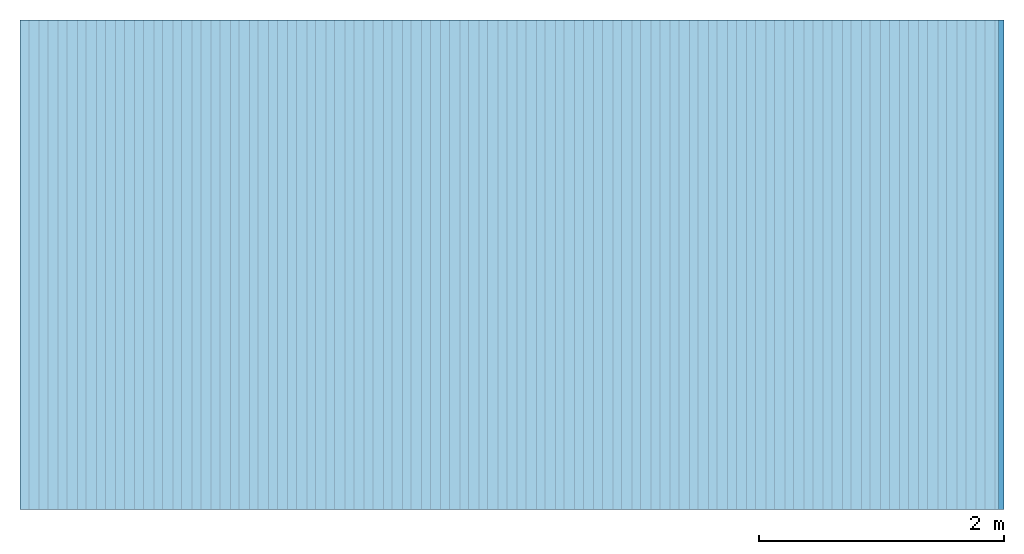
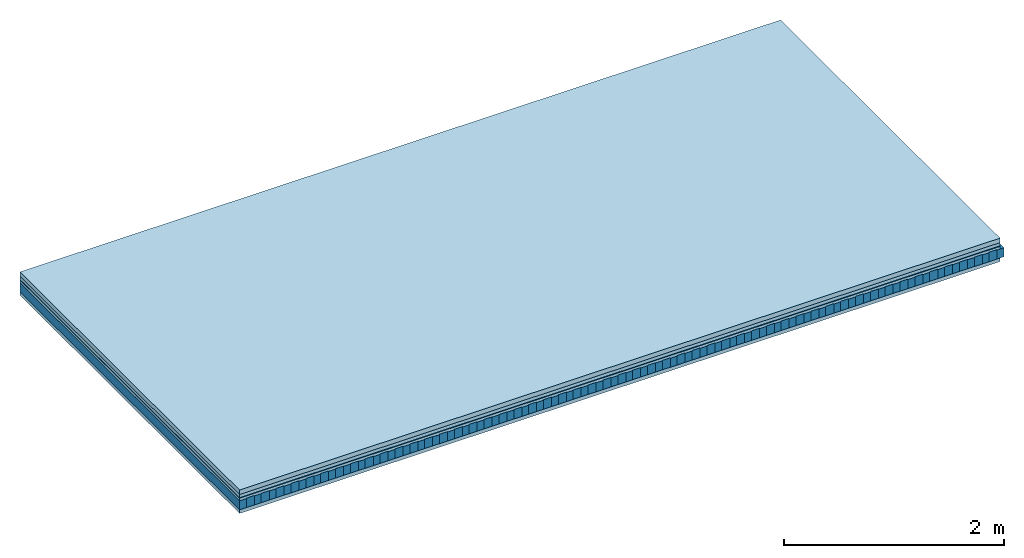
# One storey: 5 plates, 2 members, 1 element without a shape of its own.
"""IFC4 building model written with IfcOpenShell, lengths in metres."""

import ifcopenshell
import ifcopenshell.guid

model = None  # the IFC model being written
_history = None  # IfcOwnerHistory: only IFC2X3 demands one
_inside = {}  # id of a spatial element -> (the spatial element, [elements in it])
_under = {}  # id of a project, library or spatial element -> (it, [spatial elements below it])
_declared = {}  # id of a project -> (the project, [libraries it declares])
_typed = {}  # id of a type object -> (the type object, [elements of that type])
_made_of = {}  # id of a material, layer set ... -> (it, [elements and type objects made of it])


def new_model(schema):
    """Start an empty IFC model of exactly this schema.

    Asked for "IFC4X3", IfcOpenShell would pick the latest addendum, in which some entities
    have other attributes; the version numbers below select the first issue.
    IFC2X3 requires an IfcOwnerHistory on every rooted entity: one is made here for all.
    """
    global model, _history
    if schema == "IFC4X3":
        model = ifcopenshell.file(schema_version=(4, 3, 0, 0))
    else:
        model = ifcopenshell.file(schema=schema)
    _inside.clear()
    _under.clear()
    _declared.clear()
    _typed.clear()
    _made_of.clear()
    _history = None
    if model.schema == "IFC2X3":
        org = make("IfcOrganization", Name="unknown")
        user = make(
            "IfcPersonAndOrganization",
            ThePerson=make("IfcPerson", FamilyName="unknown"),
            TheOrganization=org,
        )
        app = make(
            "IfcApplication",
            ApplicationDeveloper=org,
            Version="unknown",
            ApplicationFullName="unknown",
            ApplicationIdentifier="unknown",
        )
        _history = make(
            "IfcOwnerHistory",
            OwningUser=user,
            OwningApplication=app,
            ChangeAction="ADDED",
            CreationDate=0,
        )
    return model


def make(cls, **values):
    """One entity of the class cls with the attributes given. An attribute that is None is left unset."""
    return model.create_entity(
        cls, **{name: value for name, value in values.items() if value is not None}
    )


def rooted(cls, **values):
    """An entity with a GlobalId (a new one), such as an element, a storey or a relation."""
    return make(cls, GlobalId=ifcopenshell.guid.new(), OwnerHistory=_history, **values)


def si_unit(unit_type, name, prefix=None):
    """IfcSIUnit, for example si_unit("LENGTHUNIT", "METRE", prefix="MILLI")."""
    return make("IfcSIUnit", UnitType=unit_type, Prefix=prefix, Name=name)


def derived_unit(unit_type, elements):
    """IfcDerivedUnit: a product of units, each with its exponent."""
    return make(
        "IfcDerivedUnit",
        Elements=[
            make("IfcDerivedUnitElement", Unit=unit, Exponent=power)
            for unit, power in elements
        ],
        UnitType=unit_type,
    )


def assignment(units):
    """IfcUnitAssignment: the units of a project."""
    return None if units is None else make("IfcUnitAssignment", Units=units)


def point(xyz):
    """IfcCartesianPoint."""
    return None if xyz is None else make("IfcCartesianPoint", Coordinates=xyz)


def direction(xyz):
    """IfcDirection."""
    return None if xyz is None else make("IfcDirection", DirectionRatios=xyz)


def frame(location, z_axis=None, x_axis=None):
    """IfcAxis2Placement3D, a coordinate frame: its origin and axes. An axis left out is left unset."""
    return make(
        "IfcAxis2Placement3D",
        Location=point(location),
        Axis=direction(z_axis),
        RefDirection=direction(x_axis),
    )


def frame_2d(location, x_axis=None):
    """IfcAxis2Placement2D, a coordinate frame in the plane: its origin and x axis."""
    return make(
        "IfcAxis2Placement2D", Location=point(location), RefDirection=direction(x_axis)
    )


def origin():
    """The frame at (0, 0, 0) with its axes left unset."""
    return frame((0.0, 0.0, 0.0))


def origin_with_axes():
    """The frame at (0, 0, 0) with the z axis (0, 0, 1) and the x axis (1, 0, 0) written out."""
    return frame((0.0, 0.0, 0.0), z_axis=(0.0, 0.0, 1.0), x_axis=(1.0, 0.0, 0.0))


def place(relative_to, where):
    """IfcLocalPlacement: puts the frame where relative to a parent placement (None: the world)."""
    return make(
        "IfcLocalPlacement", PlacementRelTo=relative_to, RelativePlacement=where
    )


def context(
    kind, dimensions, precision=None, world=None, true_north=None, identifier=None
):
    """IfcGeometricRepresentationContext, for example the 3D "Model" context."""
    return make(
        "IfcGeometricRepresentationContext",
        ContextIdentifier=identifier,
        ContextType=kind,
        CoordinateSpaceDimension=dimensions,
        Precision=precision,
        WorldCoordinateSystem=world,
        TrueNorth=true_north,
    )


def project(units=None, contexts=None):
    """IfcProject with its units and contexts."""
    return rooted(
        "IfcProject",
        Name="project",
        RepresentationContexts=contexts,
        UnitsInContext=assignment(units),
    )


def spatial(cls, under=None, at=None, **own):
    """A site, building, storey or space (cls), placed at a placement, below another one or the project."""
    s = rooted(cls, ObjectPlacement=at, **own)
    if under is not None:
        _under.setdefault(under.id(), (under, []))[1].append(s)
    return s


def profile(cls, at=None, kind="AREA", **sizes):
    """A parametric profile (cls). Its sizes go by their IFC names, for example OverallWidth=200.0."""
    return make(cls, ProfileType=kind, Position=at, **sizes)


def rectangle(**sizes):
    """IfcRectangleProfileDef."""
    return profile("IfcRectangleProfileDef", **sizes)


def extrude(swept, where, along, depth):
    """IfcExtrudedAreaSolid: the profile swept, set in the frame where, extruded along a direction by depth."""
    return make(
        "IfcExtrudedAreaSolid",
        SweptArea=swept,
        Position=where,
        ExtrudedDirection=direction(along),
        Depth=depth,
    )


def shape(context_of_items, identifier, shape_type, items):
    """IfcShapeRepresentation: the items that make up one representation, for example the "Body"."""
    return make(
        "IfcShapeRepresentation",
        ContextOfItems=context_of_items,
        RepresentationIdentifier=identifier,
        RepresentationType=shape_type,
        Items=items,
    )


def material(Name=None, Category=None):
    """IfcMaterial."""
    return make("IfcMaterial", Name=Name, Category=Category)


def layer(
    of_material, thickness, ventilated=None, Name=None, Category=None, Priority=None
):
    """IfcMaterialLayer: one layer of a wall or slab, of a material (None: an air gap)."""
    return make(
        "IfcMaterialLayer",
        Material=of_material,
        LayerThickness=thickness,
        IsVentilated=ventilated,
        Name=Name,
        Category=Category,
        Priority=Priority,
    )


def layer_set(layers, Name=None):
    """IfcMaterialLayerSet."""
    return make("IfcMaterialLayerSet", MaterialLayers=layers, LayerSetName=Name)


def made_of(thing, what):
    """Note that an element or type object is made of a material, layer set ...; save() writes the relation."""
    if what is not None:
        _made_of.setdefault(what.id(), (what, []))[1].append(thing)
    return thing


def type_object(cls, material=None, **own):
    """A type object (cls), such as IfcWallType, which elements share."""
    return made_of(rooted(cls, **own), material)


def element(
    cls,
    number,
    at=None,
    inside=None,
    cuts=None,
    type_object=None,
    material=None,
    context=None,
    identifier="Body",
    shape_type=None,
    held_by="IfcProductDefinitionShape",
    body=None,
    shapes=None,
    **own,
):
    """One element of the class cls, such as IfcWall. Its Tag is "e" and its number.

    at: its placement. inside: the storey or other place that contains it. cuts: it is an
    opening in that element (IfcRelVoidsElement). A single representation is given by context,
    identifier, shape_type and body (its items); several are given by shapes. held_by: the class
    of the entity that holds the representations. save() writes the other relations.
    """
    e = rooted(cls, Tag="e%d" % number, ObjectPlacement=at, **own)
    if body is not None:
        shapes = [shape(context, identifier, shape_type, body)]
    if shapes is not None:
        e.Representation = make(held_by, Representations=shapes)
    if inside is not None:
        _inside.setdefault(inside.id(), (inside, []))[1].append(e)
    if cuts is not None:
        rooted(
            "IfcRelVoidsElement", RelatingBuildingElement=cuts, RelatedOpeningElement=e
        )
    if type_object is not None:
        _typed.setdefault(type_object.id(), (type_object, []))[1].append(e)
    return made_of(e, material)


def aggregate(whole, parts):
    """IfcRelAggregates: a whole, such as a stair, and the parts it consists of."""
    return rooted("IfcRelAggregates", RelatingObject=whole, RelatedObjects=parts)


def save(model, path):
    """Write the relations noted so far, then the file.

    IfcRelAggregates (storeys below a building ...), IfcRelContainedInSpatialStructure (elements
    in a storey), IfcRelDefinesByType, IfcRelAssociatesMaterial and IfcRelDeclares: one each for
    every whole, place, type object, material and project.
    """
    for whole, parts in _under.values():
        aggregate(whole, parts)
    for where, things in _inside.values():
        rooted(
            "IfcRelContainedInSpatialStructure",
            RelatedElements=things,
            RelatingStructure=where,
        )
    for kind, things in _typed.values():
        rooted("IfcRelDefinesByType", RelatedObjects=things, RelatingType=kind)
    for what, things in _made_of.values():
        rooted("IfcRelAssociatesMaterial", RelatedObjects=things, RelatingMaterial=what)
    for by, libraries in _declared.values():
        rooted("IfcRelDeclares", RelatingContext=by, RelatedDefinitions=libraries)
    model.write(path)


model = new_model("IFC4")

# Units and contexts
plan_context = context("Plan", 3, precision=1e-05, world=origin(), true_north=direction((0.0, 1.0)))
model_context = context("Model", 3, precision=1e-05, world=origin(), true_north=direction((0.0, 1.0)))
ifc_project = project(units=[si_unit("LENGTHUNIT", "METRE"), derived_unit("SOUNDPRESSUREUNIT", [(si_unit("PRESSUREUNIT", "PASCAL", prefix="MICRO"), 0)]), si_unit("ENERGYUNIT", "JOULE", prefix="MEGA"), si_unit("MASSUNIT", "GRAM", prefix="KILO"), derived_unit("THERMALTRANSMITTANCEUNIT", [(si_unit("POWERUNIT", "WATT"), 1), (si_unit("AREAUNIT", "SQUARE_METRE"), -1), (si_unit("THERMODYNAMICTEMPERATUREUNIT", "KELVIN"), -1)]), derived_unit("AREADENSITYUNIT", [(si_unit("MASSUNIT", "GRAM", prefix="KILO"), 1), (si_unit("AREAUNIT", "SQUARE_METRE"), -1)]), derived_unit("USERDEFINED", [(si_unit("ENERGYUNIT", "JOULE", prefix="MEGA"), 1), (si_unit("AREAUNIT", "SQUARE_METRE"), -1)])], contexts=[plan_context, model_context])

# Site, building, storey
site = spatial("IfcSite", under=ifc_project)
building_placement = place(None, origin())
building = spatial("IfcBuilding", under=site, at=building_placement)
storey_placement = place(building_placement, origin())
storey = spatial("IfcBuildingStorey", under=building, at=storey_placement)

# Slab, members, plates
ifc_material_1 = material(Name="Cement screed", Category="04.006")
ifc_layer_1 = layer(ifc_material_1, 0.05, Name="On-material")
ifc_material_2 = material(Name="EP1, 35mm")
ifc_layer_2 = layer(ifc_material_2, 0.035, Name="Impact sound insulation")
ifc_material_3 = material(Name="Step 6mm", Category="10.009")
ifc_layer_3 = layer(ifc_material_3, 0.006, Name="Additional insulation")
ifc_material_4 = material()
ifc_layer_4 = layer(ifc_material_4, 0.03, Name="Sub-floor")
ifc_material_5 = material(Name="Rigid, of the art")
ifc_layer_5 = layer(ifc_material_5, 0.0, Name="Bond")
ifc_layer_6 = layer(None, 0.1, Name="Supporting structure")
ifc_layer_7 = layer(ifc_material_5, 0.0, Name="Bond")
ifc_material_6 = material(Name="panel on the underside HBF 40mm (20+20mm)", Category="07.001")
ifc_layer_8 = layer(ifc_material_6, 0.04, Name="Lower layer 1")
ifc_layer_set = layer_set([ifc_layer_1, ifc_layer_2, ifc_layer_3, ifc_layer_4, ifc_layer_5, ifc_layer_6, ifc_layer_7, ifc_layer_8])
slab_type = type_object("IfcSlabType", Name="A0085", PredefinedType="NOTDEFINED", material=ifc_layer_set)
slab_placement = place(None, frame((0.0, 0.0, 0.0), z_axis=(0.0, 0.0, -1.0), x_axis=(1.0, 0.0, 0.0)))
slab = element("IfcSlab", 1, at=slab_placement, inside=storey, type_object=slab_type, material=ifc_layer_set, Name="Slab #1")
ifc_material_7 = material(Name="Block Q4")
member_1_placement = place(slab_placement, origin())
member_1 = element("IfcMember", 2, at=member_1_placement, material=ifc_material_7, Name="Supporting structure", context=plan_context, shape_type="SweptSolid", body=[
    extrude(rectangle(XDim=0.071666666666667, YDim=0.1, at=frame_2d((0.0358333333333335, 0.05), x_axis=(1.0, 0.0))), frame((0.0, 4.0, 0.121), z_axis=(0.0, -1.0, 0.0), x_axis=(1.0, 0.0, 0.0)), (0.0, 0.0, 1.0), 4.0),
    extrude(rectangle(XDim=0.071666666666667, YDim=0.1, at=frame_2d((0.0358333333333335, 0.05), x_axis=(1.0, 0.0))), frame((0.15625, 4.0, 0.121), z_axis=(0.0, -1.0, 0.0), x_axis=(1.0, 0.0, 0.0)), (0.0, 0.0, 1.0), 4.0),
    extrude(rectangle(XDim=0.071666666666667, YDim=0.1, at=frame_2d((0.0358333333333335, 0.05), x_axis=(1.0, 0.0))), frame((0.3125, 4.0, 0.121), z_axis=(0.0, -1.0, 0.0), x_axis=(1.0, 0.0, 0.0)), (0.0, 0.0, 1.0), 4.0),
    extrude(rectangle(XDim=0.071666666666667, YDim=0.1, at=frame_2d((0.0358333333333335, 0.05), x_axis=(1.0, 0.0))), frame((0.46875, 4.0, 0.121), z_axis=(0.0, -1.0, 0.0), x_axis=(1.0, 0.0, 0.0)), (0.0, 0.0, 1.0), 4.0),
    extrude(rectangle(XDim=0.071666666666667, YDim=0.1, at=frame_2d((0.0358333333333335, 0.05), x_axis=(1.0, 0.0))), frame((0.625, 4.0, 0.121), z_axis=(0.0, -1.0, 0.0), x_axis=(1.0, 0.0, 0.0)), (0.0, 0.0, 1.0), 4.0),
    extrude(rectangle(XDim=0.071666666666667, YDim=0.1, at=frame_2d((0.0358333333333335, 0.05), x_axis=(1.0, 0.0))), frame((0.78125, 4.0, 0.121), z_axis=(0.0, -1.0, 0.0), x_axis=(1.0, 0.0, 0.0)), (0.0, 0.0, 1.0), 4.0),
    extrude(rectangle(XDim=0.071666666666667, YDim=0.1, at=frame_2d((0.0358333333333335, 0.05), x_axis=(1.0, 0.0))), frame((0.9375, 4.0, 0.121), z_axis=(0.0, -1.0, 0.0), x_axis=(1.0, 0.0, 0.0)), (0.0, 0.0, 1.0), 4.0),
    extrude(rectangle(XDim=0.071666666666667, YDim=0.1, at=frame_2d((0.0358333333333335, 0.05), x_axis=(1.0, 0.0))), frame((1.09375, 4.0, 0.121), z_axis=(0.0, -1.0, 0.0), x_axis=(1.0, 0.0, 0.0)), (0.0, 0.0, 1.0), 4.0),
    extrude(rectangle(XDim=0.071666666666667, YDim=0.1, at=frame_2d((0.0358333333333335, 0.05), x_axis=(1.0, 0.0))), frame((1.25, 4.0, 0.121), z_axis=(0.0, -1.0, 0.0), x_axis=(1.0, 0.0, 0.0)), (0.0, 0.0, 1.0), 4.0),
    extrude(rectangle(XDim=0.071666666666667, YDim=0.1, at=frame_2d((0.0358333333333335, 0.05), x_axis=(1.0, 0.0))), frame((1.40625, 4.0, 0.121), z_axis=(0.0, -1.0, 0.0), x_axis=(1.0, 0.0, 0.0)), (0.0, 0.0, 1.0), 4.0),
    extrude(rectangle(XDim=0.071666666666667, YDim=0.1, at=frame_2d((0.0358333333333335, 0.05), x_axis=(1.0, 0.0))), frame((1.5625, 4.0, 0.121), z_axis=(0.0, -1.0, 0.0), x_axis=(1.0, 0.0, 0.0)), (0.0, 0.0, 1.0), 4.0),
    extrude(rectangle(XDim=0.071666666666667, YDim=0.1, at=frame_2d((0.0358333333333335, 0.05), x_axis=(1.0, 0.0))), frame((1.71875, 4.0, 0.121), z_axis=(0.0, -1.0, 0.0), x_axis=(1.0, 0.0, 0.0)), (0.0, 0.0, 1.0), 4.0),
    extrude(rectangle(XDim=0.071666666666667, YDim=0.1, at=frame_2d((0.0358333333333335, 0.05), x_axis=(1.0, 0.0))), frame((1.875, 4.0, 0.121), z_axis=(0.0, -1.0, 0.0), x_axis=(1.0, 0.0, 0.0)), (0.0, 0.0, 1.0), 4.0),
    extrude(rectangle(XDim=0.071666666666667, YDim=0.1, at=frame_2d((0.0358333333333335, 0.05), x_axis=(1.0, 0.0))), frame((2.03125, 4.0, 0.121), z_axis=(0.0, -1.0, 0.0), x_axis=(1.0, 0.0, 0.0)), (0.0, 0.0, 1.0), 4.0),
    extrude(rectangle(XDim=0.071666666666667, YDim=0.1, at=frame_2d((0.0358333333333335, 0.05), x_axis=(1.0, 0.0))), frame((2.1875, 4.0, 0.121), z_axis=(0.0, -1.0, 0.0), x_axis=(1.0, 0.0, 0.0)), (0.0, 0.0, 1.0), 4.0),
    extrude(rectangle(XDim=0.071666666666667, YDim=0.1, at=frame_2d((0.0358333333333335, 0.05), x_axis=(1.0, 0.0))), frame((2.34375, 4.0, 0.121), z_axis=(0.0, -1.0, 0.0), x_axis=(1.0, 0.0, 0.0)), (0.0, 0.0, 1.0), 4.0),
    extrude(rectangle(XDim=0.071666666666667, YDim=0.1, at=frame_2d((0.0358333333333335, 0.05), x_axis=(1.0, 0.0))), frame((2.5, 4.0, 0.121), z_axis=(0.0, -1.0, 0.0), x_axis=(1.0, 0.0, 0.0)), (0.0, 0.0, 1.0), 4.0),
    extrude(rectangle(XDim=0.071666666666667, YDim=0.1, at=frame_2d((0.0358333333333335, 0.05), x_axis=(1.0, 0.0))), frame((2.65625, 4.0, 0.121), z_axis=(0.0, -1.0, 0.0), x_axis=(1.0, 0.0, 0.0)), (0.0, 0.0, 1.0), 4.0),
    extrude(rectangle(XDim=0.071666666666667, YDim=0.1, at=frame_2d((0.0358333333333335, 0.05), x_axis=(1.0, 0.0))), frame((2.8125, 4.0, 0.121), z_axis=(0.0, -1.0, 0.0), x_axis=(1.0, 0.0, 0.0)), (0.0, 0.0, 1.0), 4.0),
    extrude(rectangle(XDim=0.071666666666667, YDim=0.1, at=frame_2d((0.0358333333333335, 0.05), x_axis=(1.0, 0.0))), frame((2.96875, 4.0, 0.121), z_axis=(0.0, -1.0, 0.0), x_axis=(1.0, 0.0, 0.0)), (0.0, 0.0, 1.0), 4.0),
    extrude(rectangle(XDim=0.071666666666667, YDim=0.1, at=frame_2d((0.0358333333333335, 0.05), x_axis=(1.0, 0.0))), frame((3.125, 4.0, 0.121), z_axis=(0.0, -1.0, 0.0), x_axis=(1.0, 0.0, 0.0)), (0.0, 0.0, 1.0), 4.0),
    extrude(rectangle(XDim=0.071666666666667, YDim=0.1, at=frame_2d((0.0358333333333335, 0.05), x_axis=(1.0, 0.0))), frame((3.28125, 4.0, 0.121), z_axis=(0.0, -1.0, 0.0), x_axis=(1.0, 0.0, 0.0)), (0.0, 0.0, 1.0), 4.0),
    extrude(rectangle(XDim=0.071666666666667, YDim=0.1, at=frame_2d((0.0358333333333335, 0.05), x_axis=(1.0, 0.0))), frame((3.4375, 4.0, 0.121), z_axis=(0.0, -1.0, 0.0), x_axis=(1.0, 0.0, 0.0)), (0.0, 0.0, 1.0), 4.0),
    extrude(rectangle(XDim=0.071666666666667, YDim=0.1, at=frame_2d((0.0358333333333335, 0.05), x_axis=(1.0, 0.0))), frame((3.59375, 4.0, 0.121), z_axis=(0.0, -1.0, 0.0), x_axis=(1.0, 0.0, 0.0)), (0.0, 0.0, 1.0), 4.0),
    extrude(rectangle(XDim=0.071666666666667, YDim=0.1, at=frame_2d((0.0358333333333335, 0.05), x_axis=(1.0, 0.0))), frame((3.75, 4.0, 0.121), z_axis=(0.0, -1.0, 0.0), x_axis=(1.0, 0.0, 0.0)), (0.0, 0.0, 1.0), 4.0),
    extrude(rectangle(XDim=0.071666666666667, YDim=0.1, at=frame_2d((0.0358333333333335, 0.05), x_axis=(1.0, 0.0))), frame((3.90625, 4.0, 0.121), z_axis=(0.0, -1.0, 0.0), x_axis=(1.0, 0.0, 0.0)), (0.0, 0.0, 1.0), 4.0),
    extrude(rectangle(XDim=0.071666666666667, YDim=0.1, at=frame_2d((0.0358333333333335, 0.05), x_axis=(1.0, 0.0))), frame((4.0625, 4.0, 0.121), z_axis=(0.0, -1.0, 0.0), x_axis=(1.0, 0.0, 0.0)), (0.0, 0.0, 1.0), 4.0),
    extrude(rectangle(XDim=0.071666666666667, YDim=0.1, at=frame_2d((0.0358333333333335, 0.05), x_axis=(1.0, 0.0))), frame((4.21875, 4.0, 0.121), z_axis=(0.0, -1.0, 0.0), x_axis=(1.0, 0.0, 0.0)), (0.0, 0.0, 1.0), 4.0),
    extrude(rectangle(XDim=0.071666666666667, YDim=0.1, at=frame_2d((0.0358333333333335, 0.05), x_axis=(1.0, 0.0))), frame((4.375, 4.0, 0.121), z_axis=(0.0, -1.0, 0.0), x_axis=(1.0, 0.0, 0.0)), (0.0, 0.0, 1.0), 4.0),
    extrude(rectangle(XDim=0.071666666666667, YDim=0.1, at=frame_2d((0.0358333333333335, 0.05), x_axis=(1.0, 0.0))), frame((4.53125, 4.0, 0.121), z_axis=(0.0, -1.0, 0.0), x_axis=(1.0, 0.0, 0.0)), (0.0, 0.0, 1.0), 4.0),
    extrude(rectangle(XDim=0.071666666666667, YDim=0.1, at=frame_2d((0.0358333333333335, 0.05), x_axis=(1.0, 0.0))), frame((4.6875, 4.0, 0.121), z_axis=(0.0, -1.0, 0.0), x_axis=(1.0, 0.0, 0.0)), (0.0, 0.0, 1.0), 4.0),
    extrude(rectangle(XDim=0.071666666666667, YDim=0.1, at=frame_2d((0.0358333333333335, 0.05), x_axis=(1.0, 0.0))), frame((4.84375, 4.0, 0.121), z_axis=(0.0, -1.0, 0.0), x_axis=(1.0, 0.0, 0.0)), (0.0, 0.0, 1.0), 4.0),
    extrude(rectangle(XDim=0.071666666666667, YDim=0.1, at=frame_2d((0.0358333333333335, 0.05), x_axis=(1.0, 0.0))), frame((5.0, 4.0, 0.121), z_axis=(0.0, -1.0, 0.0), x_axis=(1.0, 0.0, 0.0)), (0.0, 0.0, 1.0), 4.0),
    extrude(rectangle(XDim=0.071666666666667, YDim=0.1, at=frame_2d((0.0358333333333335, 0.05), x_axis=(1.0, 0.0))), frame((5.15625, 4.0, 0.121), z_axis=(0.0, -1.0, 0.0), x_axis=(1.0, 0.0, 0.0)), (0.0, 0.0, 1.0), 4.0),
    extrude(rectangle(XDim=0.071666666666667, YDim=0.1, at=frame_2d((0.0358333333333335, 0.05), x_axis=(1.0, 0.0))), frame((5.3125, 4.0, 0.121), z_axis=(0.0, -1.0, 0.0), x_axis=(1.0, 0.0, 0.0)), (0.0, 0.0, 1.0), 4.0),
    extrude(rectangle(XDim=0.071666666666667, YDim=0.1, at=frame_2d((0.0358333333333335, 0.05), x_axis=(1.0, 0.0))), frame((5.46875, 4.0, 0.121), z_axis=(0.0, -1.0, 0.0), x_axis=(1.0, 0.0, 0.0)), (0.0, 0.0, 1.0), 4.0),
    extrude(rectangle(XDim=0.071666666666667, YDim=0.1, at=frame_2d((0.0358333333333335, 0.05), x_axis=(1.0, 0.0))), frame((5.625, 4.0, 0.121), z_axis=(0.0, -1.0, 0.0), x_axis=(1.0, 0.0, 0.0)), (0.0, 0.0, 1.0), 4.0),
    extrude(rectangle(XDim=0.071666666666667, YDim=0.1, at=frame_2d((0.0358333333333335, 0.05), x_axis=(1.0, 0.0))), frame((5.78125, 4.0, 0.121), z_axis=(0.0, -1.0, 0.0), x_axis=(1.0, 0.0, 0.0)), (0.0, 0.0, 1.0), 4.0),
    extrude(rectangle(XDim=0.071666666666667, YDim=0.1, at=frame_2d((0.0358333333333335, 0.05), x_axis=(1.0, 0.0))), frame((5.9375, 4.0, 0.121), z_axis=(0.0, -1.0, 0.0), x_axis=(1.0, 0.0, 0.0)), (0.0, 0.0, 1.0), 4.0),
    extrude(rectangle(XDim=0.071666666666667, YDim=0.1, at=frame_2d((0.0358333333333335, 0.05), x_axis=(1.0, 0.0))), frame((6.09375, 4.0, 0.121), z_axis=(0.0, -1.0, 0.0), x_axis=(1.0, 0.0, 0.0)), (0.0, 0.0, 1.0), 4.0),
    extrude(rectangle(XDim=0.071666666666667, YDim=0.1, at=frame_2d((0.0358333333333335, 0.05), x_axis=(1.0, 0.0))), frame((6.25, 4.0, 0.121), z_axis=(0.0, -1.0, 0.0), x_axis=(1.0, 0.0, 0.0)), (0.0, 0.0, 1.0), 4.0),
    extrude(rectangle(XDim=0.071666666666667, YDim=0.1, at=frame_2d((0.0358333333333335, 0.05), x_axis=(1.0, 0.0))), frame((6.40625, 4.0, 0.121), z_axis=(0.0, -1.0, 0.0), x_axis=(1.0, 0.0, 0.0)), (0.0, 0.0, 1.0), 4.0),
    extrude(rectangle(XDim=0.071666666666667, YDim=0.1, at=frame_2d((0.0358333333333335, 0.05), x_axis=(1.0, 0.0))), frame((6.5625, 4.0, 0.121), z_axis=(0.0, -1.0, 0.0), x_axis=(1.0, 0.0, 0.0)), (0.0, 0.0, 1.0), 4.0),
    extrude(rectangle(XDim=0.071666666666667, YDim=0.1, at=frame_2d((0.0358333333333335, 0.05), x_axis=(1.0, 0.0))), frame((6.71875, 4.0, 0.121), z_axis=(0.0, -1.0, 0.0), x_axis=(1.0, 0.0, 0.0)), (0.0, 0.0, 1.0), 4.0),
    extrude(rectangle(XDim=0.071666666666667, YDim=0.1, at=frame_2d((0.0358333333333335, 0.05), x_axis=(1.0, 0.0))), frame((6.875, 4.0, 0.121), z_axis=(0.0, -1.0, 0.0), x_axis=(1.0, 0.0, 0.0)), (0.0, 0.0, 1.0), 4.0),
    extrude(rectangle(XDim=0.071666666666667, YDim=0.1, at=frame_2d((0.0358333333333335, 0.05), x_axis=(1.0, 0.0))), frame((7.03125, 4.0, 0.121), z_axis=(0.0, -1.0, 0.0), x_axis=(1.0, 0.0, 0.0)), (0.0, 0.0, 1.0), 4.0),
    extrude(rectangle(XDim=0.071666666666667, YDim=0.1, at=frame_2d((0.0358333333333335, 0.05), x_axis=(1.0, 0.0))), frame((7.1875, 4.0, 0.121), z_axis=(0.0, -1.0, 0.0), x_axis=(1.0, 0.0, 0.0)), (0.0, 0.0, 1.0), 4.0),
    extrude(rectangle(XDim=0.071666666666667, YDim=0.1, at=frame_2d((0.0358333333333335, 0.05), x_axis=(1.0, 0.0))), frame((7.34375, 4.0, 0.121), z_axis=(0.0, -1.0, 0.0), x_axis=(1.0, 0.0, 0.0)), (0.0, 0.0, 1.0), 4.0),
    extrude(rectangle(XDim=0.071666666666667, YDim=0.1, at=frame_2d((0.0358333333333335, 0.05), x_axis=(1.0, 0.0))), frame((7.5, 4.0, 0.121), z_axis=(0.0, -1.0, 0.0), x_axis=(1.0, 0.0, 0.0)), (0.0, 0.0, 1.0), 4.0),
    extrude(rectangle(XDim=0.071666666666667, YDim=0.1, at=frame_2d((0.0358333333333335, 0.05), x_axis=(1.0, 0.0))), frame((7.65625, 4.0, 0.121), z_axis=(0.0, -1.0, 0.0), x_axis=(1.0, 0.0, 0.0)), (0.0, 0.0, 1.0), 4.0),
    extrude(rectangle(XDim=0.071666666666667, YDim=0.1, at=frame_2d((0.0358333333333335, 0.05), x_axis=(1.0, 0.0))), frame((7.8125, 4.0, 0.121), z_axis=(0.0, -1.0, 0.0), x_axis=(1.0, 0.0, 0.0)), (0.0, 0.0, 1.0), 4.0),
    extrude(rectangle(XDim=0.071666666666667, YDim=0.1, at=frame_2d((0.0358333333333335, 0.05), x_axis=(1.0, 0.0))), frame((7.96875, 4.0, 0.121), z_axis=(0.0, -1.0, 0.0), x_axis=(1.0, 0.0, 0.0)), (0.0, 0.0, 1.0), 4.0),
])
ifc_material_8 = material()
member_2_placement = place(slab_placement, origin())
member_2 = element("IfcMember", 3, at=member_2_placement, material=ifc_material_8, Name="in supporting structure", context=plan_context, shape_type="SweptSolid", body=[
    extrude(rectangle(XDim=0.084583333333333, YDim=0.105, at=frame_2d((0.0422916666666665, 0.0525), x_axis=(1.0, 0.0))), frame((0.071666666666667, 4.0, 0.116), z_axis=(0.0, -1.0, 0.0), x_axis=(1.0, 0.0, 0.0)), (0.0, 0.0, 1.0), 4.0),
    extrude(rectangle(XDim=0.084583333333333, YDim=0.105, at=frame_2d((0.0422916666666665, 0.0525), x_axis=(1.0, 0.0))), frame((0.227916666666667, 4.0, 0.116), z_axis=(0.0, -1.0, 0.0), x_axis=(1.0, 0.0, 0.0)), (0.0, 0.0, 1.0), 4.0),
    extrude(rectangle(XDim=0.084583333333333, YDim=0.105, at=frame_2d((0.0422916666666665, 0.0525), x_axis=(1.0, 0.0))), frame((0.384166666666667, 4.0, 0.116), z_axis=(0.0, -1.0, 0.0), x_axis=(1.0, 0.0, 0.0)), (0.0, 0.0, 1.0), 4.0),
    extrude(rectangle(XDim=0.084583333333333, YDim=0.105, at=frame_2d((0.0422916666666665, 0.0525), x_axis=(1.0, 0.0))), frame((0.540416666666667, 4.0, 0.116), z_axis=(0.0, -1.0, 0.0), x_axis=(1.0, 0.0, 0.0)), (0.0, 0.0, 1.0), 4.0),
    extrude(rectangle(XDim=0.084583333333333, YDim=0.105, at=frame_2d((0.0422916666666665, 0.0525), x_axis=(1.0, 0.0))), frame((0.696666666666667, 4.0, 0.116), z_axis=(0.0, -1.0, 0.0), x_axis=(1.0, 0.0, 0.0)), (0.0, 0.0, 1.0), 4.0),
    extrude(rectangle(XDim=0.084583333333333, YDim=0.105, at=frame_2d((0.0422916666666665, 0.0525), x_axis=(1.0, 0.0))), frame((0.852916666666667, 4.0, 0.116), z_axis=(0.0, -1.0, 0.0), x_axis=(1.0, 0.0, 0.0)), (0.0, 0.0, 1.0), 4.0),
    extrude(rectangle(XDim=0.084583333333333, YDim=0.105, at=frame_2d((0.0422916666666665, 0.0525), x_axis=(1.0, 0.0))), frame((1.00916666666667, 4.0, 0.116), z_axis=(0.0, -1.0, 0.0), x_axis=(1.0, 0.0, 0.0)), (0.0, 0.0, 1.0), 4.0),
    extrude(rectangle(XDim=0.084583333333333, YDim=0.105, at=frame_2d((0.0422916666666665, 0.0525), x_axis=(1.0, 0.0))), frame((1.16541666666667, 4.0, 0.116), z_axis=(0.0, -1.0, 0.0), x_axis=(1.0, 0.0, 0.0)), (0.0, 0.0, 1.0), 4.0),
    extrude(rectangle(XDim=0.084583333333333, YDim=0.105, at=frame_2d((0.0422916666666665, 0.0525), x_axis=(1.0, 0.0))), frame((1.32166666666667, 4.0, 0.116), z_axis=(0.0, -1.0, 0.0), x_axis=(1.0, 0.0, 0.0)), (0.0, 0.0, 1.0), 4.0),
    extrude(rectangle(XDim=0.084583333333333, YDim=0.105, at=frame_2d((0.0422916666666665, 0.0525), x_axis=(1.0, 0.0))), frame((1.47791666666667, 4.0, 0.116), z_axis=(0.0, -1.0, 0.0), x_axis=(1.0, 0.0, 0.0)), (0.0, 0.0, 1.0), 4.0),
    extrude(rectangle(XDim=0.084583333333333, YDim=0.105, at=frame_2d((0.0422916666666665, 0.0525), x_axis=(1.0, 0.0))), frame((1.63416666666667, 4.0, 0.116), z_axis=(0.0, -1.0, 0.0), x_axis=(1.0, 0.0, 0.0)), (0.0, 0.0, 1.0), 4.0),
    extrude(rectangle(XDim=0.084583333333333, YDim=0.105, at=frame_2d((0.0422916666666665, 0.0525), x_axis=(1.0, 0.0))), frame((1.79041666666667, 4.0, 0.116), z_axis=(0.0, -1.0, 0.0), x_axis=(1.0, 0.0, 0.0)), (0.0, 0.0, 1.0), 4.0),
    extrude(rectangle(XDim=0.084583333333333, YDim=0.105, at=frame_2d((0.0422916666666665, 0.0525), x_axis=(1.0, 0.0))), frame((1.94666666666667, 4.0, 0.116), z_axis=(0.0, -1.0, 0.0), x_axis=(1.0, 0.0, 0.0)), (0.0, 0.0, 1.0), 4.0),
    extrude(rectangle(XDim=0.084583333333333, YDim=0.105, at=frame_2d((0.0422916666666665, 0.0525), x_axis=(1.0, 0.0))), frame((2.10291666666667, 4.0, 0.116), z_axis=(0.0, -1.0, 0.0), x_axis=(1.0, 0.0, 0.0)), (0.0, 0.0, 1.0), 4.0),
    extrude(rectangle(XDim=0.084583333333333, YDim=0.105, at=frame_2d((0.0422916666666665, 0.0525), x_axis=(1.0, 0.0))), frame((2.25916666666667, 4.0, 0.116), z_axis=(0.0, -1.0, 0.0), x_axis=(1.0, 0.0, 0.0)), (0.0, 0.0, 1.0), 4.0),
    extrude(rectangle(XDim=0.084583333333333, YDim=0.105, at=frame_2d((0.0422916666666665, 0.0525), x_axis=(1.0, 0.0))), frame((2.41541666666667, 4.0, 0.116), z_axis=(0.0, -1.0, 0.0), x_axis=(1.0, 0.0, 0.0)), (0.0, 0.0, 1.0), 4.0),
    extrude(rectangle(XDim=0.084583333333333, YDim=0.105, at=frame_2d((0.0422916666666665, 0.0525), x_axis=(1.0, 0.0))), frame((2.57166666666667, 4.0, 0.116), z_axis=(0.0, -1.0, 0.0), x_axis=(1.0, 0.0, 0.0)), (0.0, 0.0, 1.0), 4.0),
    extrude(rectangle(XDim=0.084583333333333, YDim=0.105, at=frame_2d((0.0422916666666665, 0.0525), x_axis=(1.0, 0.0))), frame((2.72791666666667, 4.0, 0.116), z_axis=(0.0, -1.0, 0.0), x_axis=(1.0, 0.0, 0.0)), (0.0, 0.0, 1.0), 4.0),
    extrude(rectangle(XDim=0.084583333333333, YDim=0.105, at=frame_2d((0.0422916666666665, 0.0525), x_axis=(1.0, 0.0))), frame((2.88416666666667, 4.0, 0.116), z_axis=(0.0, -1.0, 0.0), x_axis=(1.0, 0.0, 0.0)), (0.0, 0.0, 1.0), 4.0),
    extrude(rectangle(XDim=0.084583333333333, YDim=0.105, at=frame_2d((0.0422916666666665, 0.0525), x_axis=(1.0, 0.0))), frame((3.04041666666667, 4.0, 0.116), z_axis=(0.0, -1.0, 0.0), x_axis=(1.0, 0.0, 0.0)), (0.0, 0.0, 1.0), 4.0),
    extrude(rectangle(XDim=0.084583333333333, YDim=0.105, at=frame_2d((0.0422916666666665, 0.0525), x_axis=(1.0, 0.0))), frame((3.19666666666667, 4.0, 0.116), z_axis=(0.0, -1.0, 0.0), x_axis=(1.0, 0.0, 0.0)), (0.0, 0.0, 1.0), 4.0),
    extrude(rectangle(XDim=0.084583333333333, YDim=0.105, at=frame_2d((0.0422916666666665, 0.0525), x_axis=(1.0, 0.0))), frame((3.35291666666667, 4.0, 0.116), z_axis=(0.0, -1.0, 0.0), x_axis=(1.0, 0.0, 0.0)), (0.0, 0.0, 1.0), 4.0),
    extrude(rectangle(XDim=0.084583333333333, YDim=0.105, at=frame_2d((0.0422916666666665, 0.0525), x_axis=(1.0, 0.0))), frame((3.50916666666667, 4.0, 0.116), z_axis=(0.0, -1.0, 0.0), x_axis=(1.0, 0.0, 0.0)), (0.0, 0.0, 1.0), 4.0),
    extrude(rectangle(XDim=0.084583333333333, YDim=0.105, at=frame_2d((0.0422916666666665, 0.0525), x_axis=(1.0, 0.0))), frame((3.66541666666667, 4.0, 0.116), z_axis=(0.0, -1.0, 0.0), x_axis=(1.0, 0.0, 0.0)), (0.0, 0.0, 1.0), 4.0),
    extrude(rectangle(XDim=0.084583333333333, YDim=0.105, at=frame_2d((0.0422916666666665, 0.0525), x_axis=(1.0, 0.0))), frame((3.82166666666667, 4.0, 0.116), z_axis=(0.0, -1.0, 0.0), x_axis=(1.0, 0.0, 0.0)), (0.0, 0.0, 1.0), 4.0),
    extrude(rectangle(XDim=0.084583333333333, YDim=0.105, at=frame_2d((0.0422916666666665, 0.0525), x_axis=(1.0, 0.0))), frame((3.97791666666667, 4.0, 0.116), z_axis=(0.0, -1.0, 0.0), x_axis=(1.0, 0.0, 0.0)), (0.0, 0.0, 1.0), 4.0),
    extrude(rectangle(XDim=0.084583333333333, YDim=0.105, at=frame_2d((0.0422916666666665, 0.0525), x_axis=(1.0, 0.0))), frame((4.13416666666667, 4.0, 0.116), z_axis=(0.0, -1.0, 0.0), x_axis=(1.0, 0.0, 0.0)), (0.0, 0.0, 1.0), 4.0),
    extrude(rectangle(XDim=0.084583333333333, YDim=0.105, at=frame_2d((0.0422916666666665, 0.0525), x_axis=(1.0, 0.0))), frame((4.29041666666667, 4.0, 0.116), z_axis=(0.0, -1.0, 0.0), x_axis=(1.0, 0.0, 0.0)), (0.0, 0.0, 1.0), 4.0),
    extrude(rectangle(XDim=0.084583333333333, YDim=0.105, at=frame_2d((0.0422916666666665, 0.0525), x_axis=(1.0, 0.0))), frame((4.44666666666667, 4.0, 0.116), z_axis=(0.0, -1.0, 0.0), x_axis=(1.0, 0.0, 0.0)), (0.0, 0.0, 1.0), 4.0),
    extrude(rectangle(XDim=0.084583333333333, YDim=0.105, at=frame_2d((0.0422916666666665, 0.0525), x_axis=(1.0, 0.0))), frame((4.60291666666667, 4.0, 0.116), z_axis=(0.0, -1.0, 0.0), x_axis=(1.0, 0.0, 0.0)), (0.0, 0.0, 1.0), 4.0),
    extrude(rectangle(XDim=0.084583333333333, YDim=0.105, at=frame_2d((0.0422916666666665, 0.0525), x_axis=(1.0, 0.0))), frame((4.75916666666667, 4.0, 0.116), z_axis=(0.0, -1.0, 0.0), x_axis=(1.0, 0.0, 0.0)), (0.0, 0.0, 1.0), 4.0),
    extrude(rectangle(XDim=0.084583333333333, YDim=0.105, at=frame_2d((0.0422916666666665, 0.0525), x_axis=(1.0, 0.0))), frame((4.91541666666667, 4.0, 0.116), z_axis=(0.0, -1.0, 0.0), x_axis=(1.0, 0.0, 0.0)), (0.0, 0.0, 1.0), 4.0),
    extrude(rectangle(XDim=0.084583333333333, YDim=0.105, at=frame_2d((0.0422916666666665, 0.0525), x_axis=(1.0, 0.0))), frame((5.07166666666667, 4.0, 0.116), z_axis=(0.0, -1.0, 0.0), x_axis=(1.0, 0.0, 0.0)), (0.0, 0.0, 1.0), 4.0),
    extrude(rectangle(XDim=0.084583333333333, YDim=0.105, at=frame_2d((0.0422916666666665, 0.0525), x_axis=(1.0, 0.0))), frame((5.22791666666667, 4.0, 0.116), z_axis=(0.0, -1.0, 0.0), x_axis=(1.0, 0.0, 0.0)), (0.0, 0.0, 1.0), 4.0),
    extrude(rectangle(XDim=0.084583333333333, YDim=0.105, at=frame_2d((0.0422916666666665, 0.0525), x_axis=(1.0, 0.0))), frame((5.38416666666667, 4.0, 0.116), z_axis=(0.0, -1.0, 0.0), x_axis=(1.0, 0.0, 0.0)), (0.0, 0.0, 1.0), 4.0),
    extrude(rectangle(XDim=0.084583333333333, YDim=0.105, at=frame_2d((0.0422916666666665, 0.0525), x_axis=(1.0, 0.0))), frame((5.54041666666667, 4.0, 0.116), z_axis=(0.0, -1.0, 0.0), x_axis=(1.0, 0.0, 0.0)), (0.0, 0.0, 1.0), 4.0),
    extrude(rectangle(XDim=0.084583333333333, YDim=0.105, at=frame_2d((0.0422916666666665, 0.0525), x_axis=(1.0, 0.0))), frame((5.69666666666667, 4.0, 0.116), z_axis=(0.0, -1.0, 0.0), x_axis=(1.0, 0.0, 0.0)), (0.0, 0.0, 1.0), 4.0),
    extrude(rectangle(XDim=0.084583333333333, YDim=0.105, at=frame_2d((0.0422916666666665, 0.0525), x_axis=(1.0, 0.0))), frame((5.85291666666667, 4.0, 0.116), z_axis=(0.0, -1.0, 0.0), x_axis=(1.0, 0.0, 0.0)), (0.0, 0.0, 1.0), 4.0),
    extrude(rectangle(XDim=0.084583333333333, YDim=0.105, at=frame_2d((0.0422916666666665, 0.0525), x_axis=(1.0, 0.0))), frame((6.00916666666667, 4.0, 0.116), z_axis=(0.0, -1.0, 0.0), x_axis=(1.0, 0.0, 0.0)), (0.0, 0.0, 1.0), 4.0),
    extrude(rectangle(XDim=0.084583333333333, YDim=0.105, at=frame_2d((0.0422916666666665, 0.0525), x_axis=(1.0, 0.0))), frame((6.16541666666667, 4.0, 0.116), z_axis=(0.0, -1.0, 0.0), x_axis=(1.0, 0.0, 0.0)), (0.0, 0.0, 1.0), 4.0),
    extrude(rectangle(XDim=0.084583333333333, YDim=0.105, at=frame_2d((0.0422916666666665, 0.0525), x_axis=(1.0, 0.0))), frame((6.32166666666667, 4.0, 0.116), z_axis=(0.0, -1.0, 0.0), x_axis=(1.0, 0.0, 0.0)), (0.0, 0.0, 1.0), 4.0),
    extrude(rectangle(XDim=0.084583333333333, YDim=0.105, at=frame_2d((0.0422916666666665, 0.0525), x_axis=(1.0, 0.0))), frame((6.47791666666667, 4.0, 0.116), z_axis=(0.0, -1.0, 0.0), x_axis=(1.0, 0.0, 0.0)), (0.0, 0.0, 1.0), 4.0),
    extrude(rectangle(XDim=0.084583333333333, YDim=0.105, at=frame_2d((0.0422916666666665, 0.0525), x_axis=(1.0, 0.0))), frame((6.63416666666667, 4.0, 0.116), z_axis=(0.0, -1.0, 0.0), x_axis=(1.0, 0.0, 0.0)), (0.0, 0.0, 1.0), 4.0),
    extrude(rectangle(XDim=0.084583333333333, YDim=0.105, at=frame_2d((0.0422916666666665, 0.0525), x_axis=(1.0, 0.0))), frame((6.79041666666667, 4.0, 0.116), z_axis=(0.0, -1.0, 0.0), x_axis=(1.0, 0.0, 0.0)), (0.0, 0.0, 1.0), 4.0),
    extrude(rectangle(XDim=0.084583333333333, YDim=0.105, at=frame_2d((0.0422916666666665, 0.0525), x_axis=(1.0, 0.0))), frame((6.94666666666667, 4.0, 0.116), z_axis=(0.0, -1.0, 0.0), x_axis=(1.0, 0.0, 0.0)), (0.0, 0.0, 1.0), 4.0),
    extrude(rectangle(XDim=0.084583333333333, YDim=0.105, at=frame_2d((0.0422916666666665, 0.0525), x_axis=(1.0, 0.0))), frame((7.10291666666667, 4.0, 0.116), z_axis=(0.0, -1.0, 0.0), x_axis=(1.0, 0.0, 0.0)), (0.0, 0.0, 1.0), 4.0),
    extrude(rectangle(XDim=0.084583333333333, YDim=0.105, at=frame_2d((0.0422916666666665, 0.0525), x_axis=(1.0, 0.0))), frame((7.25916666666667, 4.0, 0.116), z_axis=(0.0, -1.0, 0.0), x_axis=(1.0, 0.0, 0.0)), (0.0, 0.0, 1.0), 4.0),
    extrude(rectangle(XDim=0.084583333333333, YDim=0.105, at=frame_2d((0.0422916666666665, 0.0525), x_axis=(1.0, 0.0))), frame((7.41541666666667, 4.0, 0.116), z_axis=(0.0, -1.0, 0.0), x_axis=(1.0, 0.0, 0.0)), (0.0, 0.0, 1.0), 4.0),
    extrude(rectangle(XDim=0.084583333333333, YDim=0.105, at=frame_2d((0.0422916666666665, 0.0525), x_axis=(1.0, 0.0))), frame((7.57166666666667, 4.0, 0.116), z_axis=(0.0, -1.0, 0.0), x_axis=(1.0, 0.0, 0.0)), (0.0, 0.0, 1.0), 4.0),
    extrude(rectangle(XDim=0.084583333333333, YDim=0.105, at=frame_2d((0.0422916666666665, 0.0525), x_axis=(1.0, 0.0))), frame((7.72791666666667, 4.0, 0.116), z_axis=(0.0, -1.0, 0.0), x_axis=(1.0, 0.0, 0.0)), (0.0, 0.0, 1.0), 4.0),
    extrude(rectangle(XDim=0.084583333333333, YDim=0.105, at=frame_2d((0.0422916666666665, 0.0525), x_axis=(1.0, 0.0))), frame((7.88416666666667, 4.0, 0.116), z_axis=(0.0, -1.0, 0.0), x_axis=(1.0, 0.0, 0.0)), (0.0, 0.0, 1.0), 4.0),
])
plate_1_placement = place(slab_placement, origin())
plate_1 = element("IfcPlate", 4, at=plate_1_placement, material=ifc_material_1, Name="On-material", context=plan_context, shape_type="SweptSolid", body=[
    extrude(rectangle(XDim=8.0, YDim=4.0, at=frame_2d((4.0, 2.0), x_axis=(1.0, 0.0))), origin_with_axes(), (0.0, 0.0, 1.0), 0.05),
])
plate_2_placement = place(slab_placement, origin())
plate_2 = element("IfcPlate", 5, at=plate_2_placement, material=ifc_material_2, Name="Impact sound insulation", context=plan_context, shape_type="SweptSolid", body=[
    extrude(rectangle(XDim=8.0, YDim=4.0, at=frame_2d((4.0, 2.0), x_axis=(1.0, 0.0))), frame((0.0, 0.0, 0.05), z_axis=(0.0, 0.0, 1.0), x_axis=(1.0, 0.0, 0.0)), (0.0, 0.0, 1.0), 0.035),
])
plate_3_placement = place(slab_placement, origin())
plate_3 = element("IfcPlate", 6, at=plate_3_placement, material=ifc_material_3, Name="Additional insulation", context=plan_context, shape_type="SweptSolid", body=[
    extrude(rectangle(XDim=8.0, YDim=4.0, at=frame_2d((4.0, 2.0), x_axis=(1.0, 0.0))), frame((0.0, 0.0, 0.085), z_axis=(0.0, 0.0, 1.0), x_axis=(1.0, 0.0, 0.0)), (0.0, 0.0, 1.0), 0.006),
])
plate_4_placement = place(slab_placement, origin())
plate_4 = element("IfcPlate", 7, at=plate_4_placement, material=ifc_material_4, Name="Sub-floor", context=plan_context, shape_type="SweptSolid", body=[
    extrude(rectangle(XDim=8.0, YDim=4.0, at=frame_2d((4.0, 2.0), x_axis=(1.0, 0.0))), frame((0.0, 0.0, 0.091), z_axis=(0.0, 0.0, 1.0), x_axis=(1.0, 0.0, 0.0)), (0.0, 0.0, 1.0), 0.03),
])
plate_5_placement = place(slab_placement, origin())
plate_5 = element("IfcPlate", 8, at=plate_5_placement, material=ifc_material_6, Name="Lower layer 1", context=plan_context, shape_type="SweptSolid", body=[
    extrude(rectangle(XDim=8.0, YDim=4.0, at=frame_2d((4.0, 2.0), x_axis=(1.0, 0.0))), frame((0.0, 0.0, 0.221), z_axis=(0.0, 0.0, 1.0), x_axis=(1.0, 0.0, 0.0)), (0.0, 0.0, 1.0), 0.04),
])
aggregate(slab, [plate_1, plate_2, plate_3, plate_4, member_1, member_2, plate_5])

save(model, "model.ifc")
